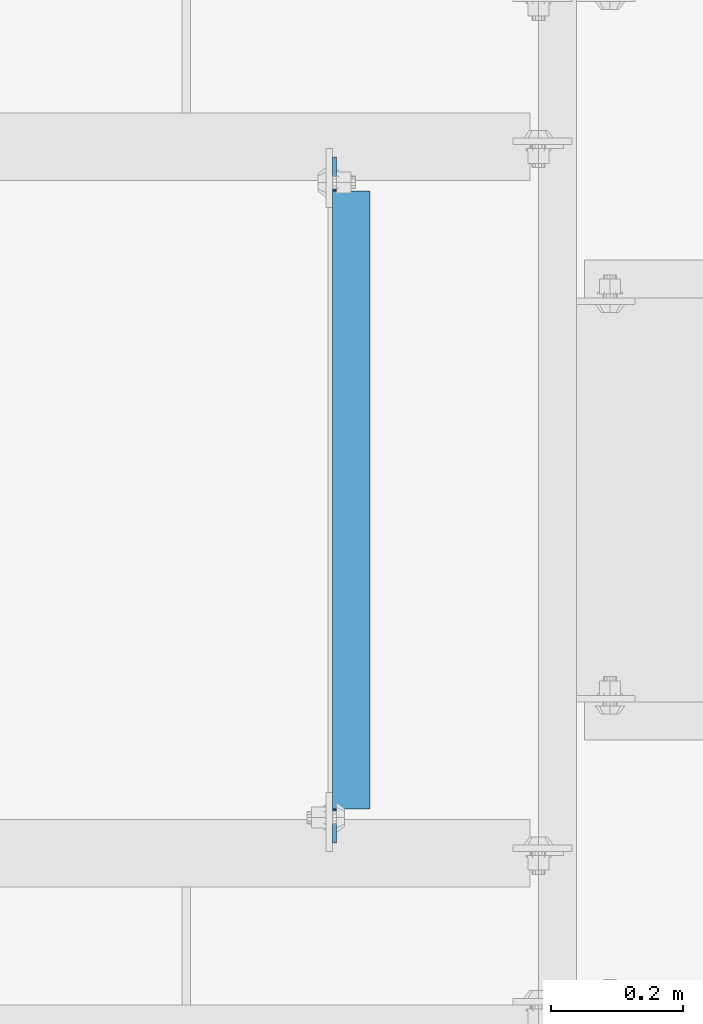
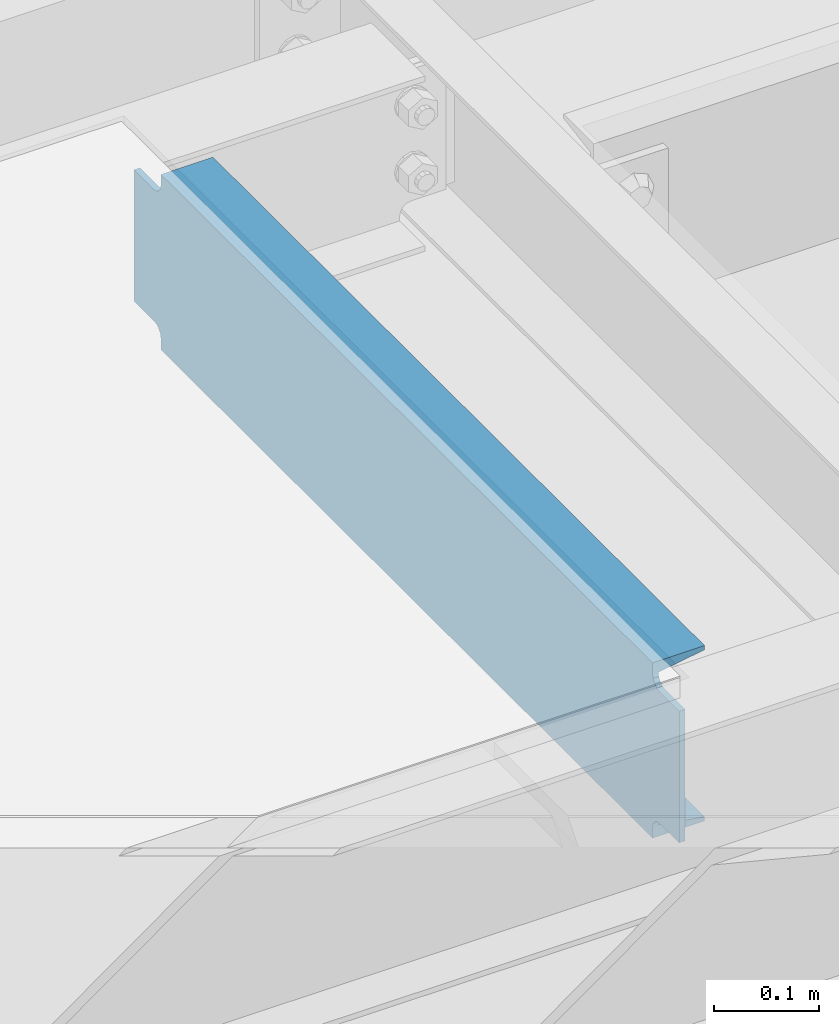
# One storey, part 919 of 1876: 1 beam, 1 element without a shape of its own.
"""IFC2X3 building model written with IfcOpenShell, lengths in millimetres."""

import ifcopenshell
import ifcopenshell.guid

model = None  # the IFC model being written
_history = None  # IfcOwnerHistory: only IFC2X3 demands one
_inside = {}  # id of a spatial element -> (the spatial element, [elements in it])
_under = {}  # id of a project, library or spatial element -> (it, [spatial elements below it])
_declared = {}  # id of a project -> (the project, [libraries it declares])
_typed = {}  # id of a type object -> (the type object, [elements of that type])
_made_of = {}  # id of a material, layer set ... -> (it, [elements and type objects made of it])


def new_model(schema):
    """Start an empty IFC model of exactly this schema.

    Asked for "IFC4X3", IfcOpenShell would pick the latest addendum, in which some entities
    have other attributes; the version numbers below select the first issue.
    IFC2X3 requires an IfcOwnerHistory on every rooted entity: one is made here for all.
    """
    global model, _history
    if schema == "IFC4X3":
        model = ifcopenshell.file(schema_version=(4, 3, 0, 0))
    else:
        model = ifcopenshell.file(schema=schema)
    _inside.clear()
    _under.clear()
    _declared.clear()
    _typed.clear()
    _made_of.clear()
    _history = None
    if model.schema == "IFC2X3":
        org = make("IfcOrganization", Name="unknown")
        user = make(
            "IfcPersonAndOrganization",
            ThePerson=make("IfcPerson", FamilyName="unknown"),
            TheOrganization=org,
        )
        app = make(
            "IfcApplication",
            ApplicationDeveloper=org,
            Version="unknown",
            ApplicationFullName="unknown",
            ApplicationIdentifier="unknown",
        )
        _history = make(
            "IfcOwnerHistory",
            OwningUser=user,
            OwningApplication=app,
            ChangeAction="ADDED",
            CreationDate=0,
        )
    return model


def make(cls, **values):
    """One entity of the class cls with the attributes given. An attribute that is None is left unset."""
    return model.create_entity(
        cls, **{name: value for name, value in values.items() if value is not None}
    )


def rooted(cls, **values):
    """An entity with a GlobalId (a new one), such as an element, a storey or a relation."""
    return make(cls, GlobalId=ifcopenshell.guid.new(), OwnerHistory=_history, **values)


def si_unit(unit_type, name, prefix=None):
    """IfcSIUnit, for example si_unit("LENGTHUNIT", "METRE", prefix="MILLI")."""
    return make("IfcSIUnit", UnitType=unit_type, Prefix=prefix, Name=name)


def assignment(units):
    """IfcUnitAssignment: the units of a project."""
    return None if units is None else make("IfcUnitAssignment", Units=units)


def point(xyz):
    """IfcCartesianPoint."""
    return None if xyz is None else make("IfcCartesianPoint", Coordinates=xyz)


def direction(xyz):
    """IfcDirection."""
    return None if xyz is None else make("IfcDirection", DirectionRatios=xyz)


def frame(location, z_axis=None, x_axis=None):
    """IfcAxis2Placement3D, a coordinate frame: its origin and axes. An axis left out is left unset."""
    return make(
        "IfcAxis2Placement3D",
        Location=point(location),
        Axis=direction(z_axis),
        RefDirection=direction(x_axis),
    )


def origin_with_axes():
    """The frame at (0, 0, 0) with the z axis (0, 0, 1) and the x axis (1, 0, 0) written out."""
    return frame((0.0, 0.0, 0.0), z_axis=(0.0, 0.0, 1.0), x_axis=(1.0, 0.0, 0.0))


def place(relative_to, where):
    """IfcLocalPlacement: puts the frame where relative to a parent placement (None: the world)."""
    return make(
        "IfcLocalPlacement", PlacementRelTo=relative_to, RelativePlacement=where
    )


def context(
    kind, dimensions, precision=None, world=None, true_north=None, identifier=None
):
    """IfcGeometricRepresentationContext, for example the 3D "Model" context."""
    return make(
        "IfcGeometricRepresentationContext",
        ContextIdentifier=identifier,
        ContextType=kind,
        CoordinateSpaceDimension=dimensions,
        Precision=precision,
        WorldCoordinateSystem=world,
        TrueNorth=true_north,
    )


def subcontext(parent, identifier, kind, view, scale=None):
    """IfcGeometricRepresentationSubContext, for example "Body" below "Model"."""
    return make(
        "IfcGeometricRepresentationSubContext",
        ContextIdentifier=identifier,
        ContextType=kind,
        ParentContext=parent,
        TargetScale=scale,
        TargetView=view,
    )


def project(units=None, contexts=None):
    """IfcProject with its units and contexts."""
    return rooted(
        "IfcProject",
        Name="project",
        RepresentationContexts=contexts,
        UnitsInContext=assignment(units),
    )


def spatial(cls, under=None, at=None, **own):
    """A site, building, storey or space (cls), placed at a placement, below another one or the project."""
    s = rooted(cls, ObjectPlacement=at, **own)
    if under is not None:
        _under.setdefault(under.id(), (under, []))[1].append(s)
    return s


def faces_of(points, faces, orient=None, outer=None):
    """IfcFace entities. A face is a list of loops; a loop is a list of indices into points, from 0.

    orient and outer hold one flag for each loop. By default every Orientation is true, the
    first loop of a face is its IfcFaceOuterBound and the others are IfcFaceBound.
    """
    made = []
    for i, loops in enumerate(faces):
        bounds = []
        for j, loop in enumerate(loops):
            is_outer = j == 0 if outer is None else outer[i][j]
            bounds.append(
                make(
                    "IfcFaceOuterBound" if is_outer else "IfcFaceBound",
                    Bound=make("IfcPolyLoop", Polygon=[points[k] for k in loop]),
                    Orientation=True if orient is None else orient[i][j],
                )
            )
        made.append(make("IfcFace", Bounds=bounds))
    return made


def faceted_brep(points, faces, orient=None, outer=None, voids=None):
    """IfcFacetedBrep: a solid bounded by flat faces; with voids (closed shells), ...WithVoids."""
    shared = [point(p) for p in points]
    hull = make("IfcClosedShell", CfsFaces=faces_of(shared, faces, orient, outer))
    if voids is None:
        return make("IfcFacetedBrep", Outer=hull)
    return make(
        "IfcFacetedBrepWithVoids",
        Outer=hull,
        Voids=[
            make(cls, CfsFaces=faces_of(shared, fs, o, b)) for cls, fs, o, b in voids
        ],
    )


def shape(context_of_items, identifier, shape_type, items):
    """IfcShapeRepresentation: the items that make up one representation, for example the "Body"."""
    return make(
        "IfcShapeRepresentation",
        ContextOfItems=context_of_items,
        RepresentationIdentifier=identifier,
        RepresentationType=shape_type,
        Items=items,
    )


def material(Name=None, Category=None):
    """IfcMaterial."""
    return make("IfcMaterial", Name=Name, Category=Category)


def made_of(thing, what):
    """Note that an element or type object is made of a material, layer set ...; save() writes the relation."""
    if what is not None:
        _made_of.setdefault(what.id(), (what, []))[1].append(thing)
    return thing


def type_object(cls, material=None, **own):
    """A type object (cls), such as IfcWallType, which elements share."""
    return made_of(rooted(cls, **own), material)


def element(
    cls,
    number,
    at=None,
    inside=None,
    cuts=None,
    type_object=None,
    material=None,
    context=None,
    identifier="Body",
    shape_type=None,
    held_by="IfcProductDefinitionShape",
    body=None,
    shapes=None,
    **own,
):
    """One element of the class cls, such as IfcWall. Its Tag is "e" and its number.

    at: its placement. inside: the storey or other place that contains it. cuts: it is an
    opening in that element (IfcRelVoidsElement). A single representation is given by context,
    identifier, shape_type and body (its items); several are given by shapes. held_by: the class
    of the entity that holds the representations. save() writes the other relations.
    """
    e = rooted(cls, Tag="e%d" % number, ObjectPlacement=at, **own)
    if body is not None:
        shapes = [shape(context, identifier, shape_type, body)]
    if shapes is not None:
        e.Representation = make(held_by, Representations=shapes)
    if inside is not None:
        _inside.setdefault(inside.id(), (inside, []))[1].append(e)
    if cuts is not None:
        rooted(
            "IfcRelVoidsElement", RelatingBuildingElement=cuts, RelatedOpeningElement=e
        )
    if type_object is not None:
        _typed.setdefault(type_object.id(), (type_object, []))[1].append(e)
    return made_of(e, material)


def aggregate(whole, parts):
    """IfcRelAggregates: a whole, such as a stair, and the parts it consists of."""
    return rooted("IfcRelAggregates", RelatingObject=whole, RelatedObjects=parts)


def save(model, path):
    """Write the relations noted so far, then the file.

    IfcRelAggregates (storeys below a building ...), IfcRelContainedInSpatialStructure (elements
    in a storey), IfcRelDefinesByType, IfcRelAssociatesMaterial and IfcRelDeclares: one each for
    every whole, place, type object, material and project.
    """
    for whole, parts in _under.values():
        aggregate(whole, parts)
    for where, things in _inside.values():
        rooted(
            "IfcRelContainedInSpatialStructure",
            RelatedElements=things,
            RelatingStructure=where,
        )
    for kind, things in _typed.values():
        rooted("IfcRelDefinesByType", RelatedObjects=things, RelatingType=kind)
    for what, things in _made_of.values():
        rooted("IfcRelAssociatesMaterial", RelatedObjects=things, RelatingMaterial=what)
    for by, libraries in _declared.values():
        rooted("IfcRelDeclares", RelatingContext=by, RelatedDefinitions=libraries)
    model.write(path)


model = new_model("IFC2X3")

# Units and contexts
model_context = context("Model", 3, precision=1e-05, world=origin_with_axes())
body_context = subcontext(model_context, "Body", "Model", "MODEL_VIEW")
ifc_project = project(units=[si_unit("LENGTHUNIT", "METRE", prefix="MILLI"), si_unit("AREAUNIT", "SQUARE_METRE"), si_unit("VOLUMEUNIT", "CUBIC_METRE"), si_unit("MASSUNIT", "GRAM", prefix="KILO"), si_unit("TIMEUNIT", "SECOND"), si_unit("PLANEANGLEUNIT", "RADIAN"), si_unit("SOLIDANGLEUNIT", "STERADIAN"), si_unit("THERMODYNAMICTEMPERATUREUNIT", "DEGREE_CELSIUS"), si_unit("LUMINOUSINTENSITYUNIT", "LUMEN")], contexts=[model_context])

# Site, building, storey
site_placement = place(None, origin_with_axes())
site = spatial("IfcSite", under=ifc_project, at=site_placement, CompositionType="ELEMENT")
building_placement = place(site_placement, origin_with_axes())
building = spatial("IfcBuilding", under=site, at=building_placement, Name="Undefined", CompositionType="ELEMENT")
storey_placement = place(building_placement, origin_with_axes())
storey = spatial("IfcBuildingStorey", under=building, at=storey_placement, Name="Undefined", CompositionType="ELEMENT", Elevation=0.0)

# Assembly, beam
assembly_placement = place(storey_placement, origin_with_axes())
assembly = element("IfcElementAssembly", 1, at=assembly_placement, inside=storey, Name="BEAM", AssemblyPlace="NOTDEFINED", PredefinedType="RIGID_FRAME")
ifc_material = material(Name="STEEL/A36")
beam_type = type_object("IfcBeamType", Name="C8X11.5", PredefinedType="NOTDEFINED")
beam_placement = place(assembly_placement, frame((4537.07643150122, -14122.3644042969, 7896.225), z_axis=(0.0, 0.0, 1.0), x_axis=(0.0, 1.0, 0.0)))
beam = element("IfcBeam", 2, at=beam_placement, type_object=beam_type, material=ifc_material, Name="BEAM", ObjectType="C8X11.5", context=body_context, shape_type="Brep", body=[
    faceted_brep([(1000.125, -28.5749999999998, -96.8355949999996), (1000.125, -28.5749999999998, -101.6), (1000.125, 28.5749999999998, -101.6), (1000.125, 28.5749999999998, -88.899999809264), (1000.125, 19.0576241940935, -88.899999809264), (1000.22996303464, 22.2250000000004, -88.3723149999996), (1001.09172992259, 28.5749999999998, -84.0399202912186), (1001.09172992259, 22.2250000000004, -84.0399202912186), (1003.84474382307, 28.5749999999998, -79.9197438230649), (1003.84474382307, 22.2250000000004, -79.9197438230649), (1007.96492029122, 28.5749999999998, -77.1667299225865), (1007.96492029122, 22.2250000000004, -77.1667299225865), (1012.82499980927, 28.5749999999998, -76.1999999999989), (1012.82499980927, 22.2250000000004, -76.1999999999989), (1050.925, 22.2250000000004, -76.1999999999989), (1050.925, 28.5749999999998, -76.1999999999989), (1000.125, -28.5749999999998, 101.6), (1000.125, 28.5749999999998, 101.6), (66.6750000000029, 28.5749999999998, 101.6), (66.6750000000029, -28.5749999999998, 101.6), (66.6750000000029, 19.0576241940935, -88.899999809264), (66.6750000000029, 28.5749999999998, -88.899999809264), (66.6750000000029, 28.5749999999998, -101.6), (66.6750000000029, -28.5749999999998, -101.6), (66.6750000000029, -28.5749999999998, -96.8355949999996), (66.5700369653623, 22.2250000000004, -88.3723149999996), (65.7082700774154, 22.2250000000004, -84.0399202912186), (65.7082700774154, 28.5749999999998, -84.0399202912186), (62.9552561769378, 22.2250000000004, -79.9197438230649), (62.9552561769378, 28.5749999999998, -79.9197438230649), (58.8350797087842, 22.2250000000004, -77.1667299225865), (58.8350797087842, 28.5749999999998, -77.1667299225865), (53.9750001907378, 22.2250000000004, -76.1999999999989), (53.9750001907378, 28.5749999999998, -76.1999999999989), (15.875, 22.2250000000004, -76.1999999999989), (15.875, 28.5749999999998, -76.1999999999989), (15.875, 22.2250000000004, 76.2000000000007), (15.875, 28.5749999999998, 76.2000000000007), (53.9750001907378, 22.2250000000004, 76.2000000000007), (53.9750001907378, 28.5749999999998, 76.2000000000007), (58.8350797087842, 22.2250000000004, 77.1667299225883), (58.8350797087842, 28.5749999999998, 77.1667299225883), (62.9552561769378, 22.2250000000004, 79.9197438230667), (62.9552561769378, 28.5749999999998, 79.9197438230667), (65.7082700774154, 22.2250000000004, 84.0399202912204), (65.7082700774154, 28.5749999999998, 84.0399202912204), (66.6750000000029, 19.0576241940826, 88.8999998092659), (66.6750000000029, 28.5749999999998, 88.8999998092659), (66.5700369653623, 22.2250000000004, 88.3723149999996), (66.6750000000029, -28.5749999999998, 96.8355949999996), (1000.125, -28.5749999999998, 96.8355949999996), (1000.125, 19.0576241940826, 88.8999998092659), (1000.125, 28.5749999999998, 88.8999998092659), (1000.22996303464, 22.2250000000004, 88.3723149999996), (1001.09172992259, 22.2250000000004, 84.0399202912204), (1001.09172992259, 28.5749999999998, 84.0399202912204), (1003.84474382307, 22.2250000000004, 79.9197438230667), (1003.84474382307, 28.5749999999998, 79.9197438230667), (1007.96492029122, 22.2250000000004, 77.1667299225883), (1007.96492029122, 28.5749999999998, 77.1667299225883), (1012.82499980927, 22.2250000000004, 76.2000000000007), (1012.82499980927, 28.5749999999998, 76.2000000000007), (1050.925, 22.2250000000004, 76.2000000000007), (1050.925, 28.5749999999998, 76.2000000000007)], [[[0, 1, 2, 3, 4]], [[5, 4, 3, 6, 7]], [[7, 6, 8, 9]], [[9, 8, 10, 11]], [[11, 10, 12, 13]], [[14, 13, 12, 15]], [[16, 17, 18, 19]], [[20, 21, 22, 23, 24]], [[25, 26, 27, 21, 20]], [[28, 29, 27, 26]], [[30, 31, 29, 28]], [[32, 33, 31, 30]], [[34, 35, 33, 32]], [[36, 37, 35, 34]], [[38, 39, 37, 36]], [[40, 41, 39, 38]], [[42, 43, 41, 40]], [[44, 45, 43, 42]], [[46, 47, 45, 44, 48]], [[19, 18, 47, 46, 49]], [[50, 16, 19, 49]], [[16, 50, 51, 52, 17]], [[48, 53, 51, 50, 49, 46]], [[54, 55, 52, 51, 53]], [[56, 57, 55, 54]], [[58, 59, 57, 56]], [[60, 61, 59, 58]], [[62, 63, 61, 60]], [[63, 62, 14, 15]], [[29, 31, 33, 35, 37, 39, 41, 43, 45, 47, 18, 17, 52, 55, 57, 59, 61, 63, 15, 12, 10, 8, 6, 3, 2, 22, 21, 27]], [[2, 1, 23, 22]], [[1, 0, 24, 23]], [[24, 0, 4, 5, 25, 20]], [[5, 7, 9, 11, 13, 14, 62, 60, 58, 56, 54, 53, 48, 44, 42, 40, 38, 36, 34, 32, 30, 28, 26, 25]]]),
])
aggregate(assembly, [beam])

save(model, "model.ifc")
